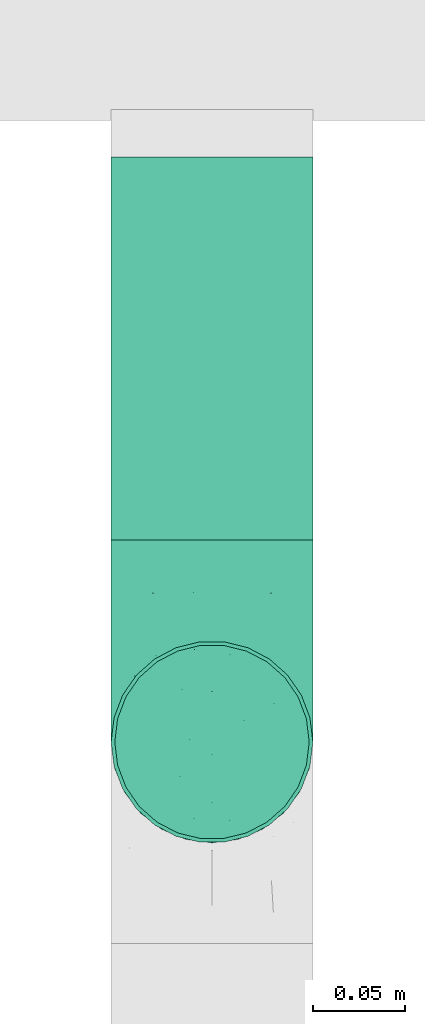
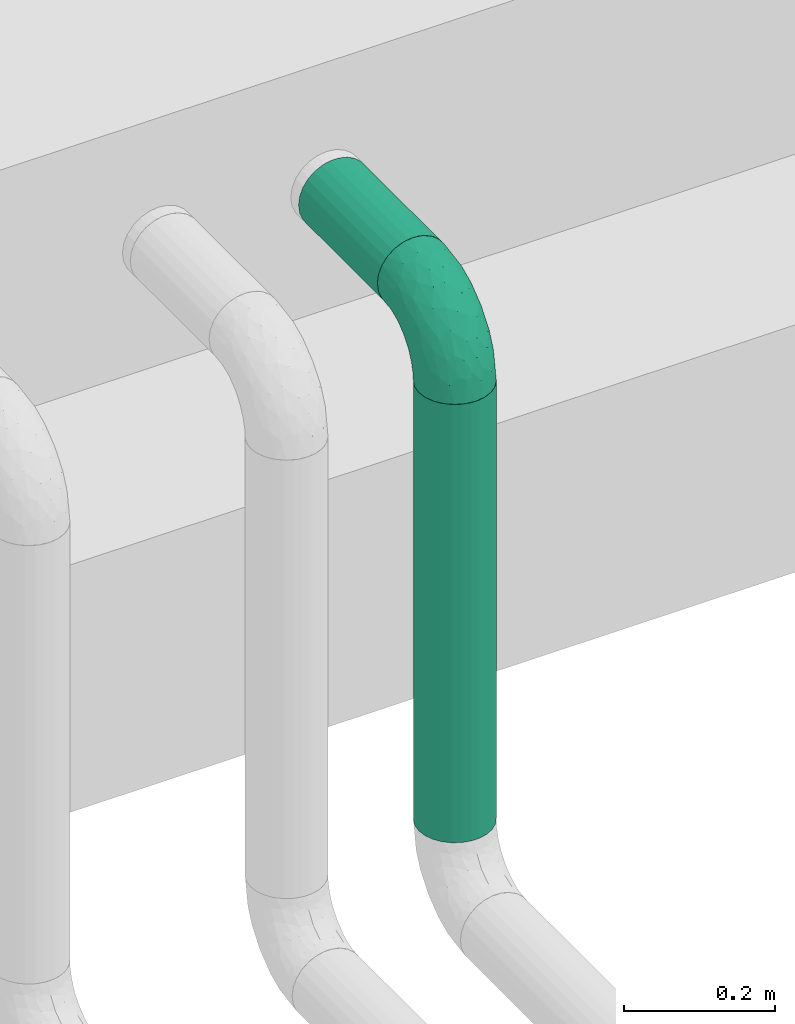
# One storey, part 11 of 91: 2 flow segments, 1 flow fitting.
"""IFC2X3 building model written with IfcOpenShell, lengths in millimetres."""

from ifc_helpers import new_model, entity, si_unit, converted_unit, derived_unit, direction, frame, origin_with_axes, origin_2d_with_axis, place, context, subcontext, project, spatial, hollow_circle, extrude, open_shell, surface_model, source, transform, mapped, material, layer, layer_set, layer_usage, type_object, element, save


model = new_model("IFC2X3")

# Units and contexts
model_context = context("Model", 3, precision=1e-05, world=origin_with_axes(), true_north=direction((0.0, 1.0)))
body_context = subcontext(model_context, "Body", "Model", "MODEL_VIEW")
ifc_project = project(units=[si_unit("AREAUNIT", "SQUARE_METRE"), si_unit("VOLUMEUNIT", "CUBIC_METRE", prefix="DECI"), si_unit("TIMEUNIT", "SECOND"), si_unit("THERMODYNAMICTEMPERATUREUNIT", "DEGREE_CELSIUS"), si_unit("PRESSUREUNIT", "PASCAL"), si_unit("MASSUNIT", "GRAM", prefix="KILO"), si_unit("LENGTHUNIT", "METRE", prefix="MILLI"), si_unit("POWERUNIT", "WATT"), si_unit("ELECTRICCURRENTUNIT", "AMPERE"), si_unit("ELECTRICVOLTAGEUNIT", "VOLT"), derived_unit("VOLUMETRICFLOWRATEUNIT", [(si_unit("VOLUMEUNIT", "CUBIC_METRE", prefix="DECI"), 1), (si_unit("TIMEUNIT", "SECOND"), -1)]), derived_unit("LINEARVELOCITYUNIT", [(si_unit("LENGTHUNIT", "METRE"), 1), (si_unit("TIMEUNIT", "SECOND"), -1)]), derived_unit("MASSDENSITYUNIT", [(si_unit("MASSUNIT", "GRAM", prefix="KILO"), 1), (si_unit("VOLUMEUNIT", "CUBIC_METRE"), -1)]), converted_unit("PLANEANGLEUNIT", "DEGREE", entity("IfcRatioMeasure", 0.01745), si_unit("PLANEANGLEUNIT", "RADIAN"), dimensions=[0, 0, 0, 0, 0, 0, 0])], contexts=[model_context])

# Site, building, storey
site_placement = place(None, origin_with_axes())
site = spatial("IfcSite", under=ifc_project, at=site_placement, CompositionType="ELEMENT")
building_placement = place(site_placement, origin_with_axes())
building = spatial("IfcBuilding", under=site, at=building_placement, Name="mc-building", CompositionType="ELEMENT")
storey_placement = place(building_placement, frame((0.0, 0.0, 8700.0), z_axis=(0.0, 0.0, 1.0), x_axis=(1.0, 0.0, 0.0)))
storey = spatial("IfcBuildingStorey", under=building, at=storey_placement, CompositionType="ELEMENT", Elevation=8700.0)

# Flow segments
ifc_material = material(Name="FZ1")
ifc_layer = layer(ifc_material, 0.0)
ifc_layer_set = layer_set([ifc_layer], Name="FZ1")
ifc_layer_usage = layer_usage(ifc_layer_set, "AXIS1", "POSITIVE", 0.0)
duct_segment_type = type_object("IfcDuctSegmentType", PredefinedType="RIGIDSEGMENT")
shared_shape_1 = source(origin_with_axes(), body_context, "Body", "SweptSolid", [
    extrude(hollow_circle(Radius=55.0, WallThickness=2.0, at=origin_2d_with_axis()), frame((0.0, 0.0, 0.0), z_axis=(1.0, 0.0, 0.0), x_axis=(0.0, 1.0, 0.0)), (0.0, 0.0, 1.0), 709.0),
])
flow_segment_1_placement = place(storey_placement, frame((9245.0, 2612.35324, 1234.0), z_axis=(0.0, 1.0, 0.0), x_axis=(0.0, 0.0, -1.0)))
element("IfcFlowSegment", 1, at=flow_segment_1_placement, inside=storey, type_object=duct_segment_type, material=ifc_layer_usage, context=body_context, shape_type="MappedRepresentation", body=[
    mapped(shared_shape_1, transform((0.0, 0.0, 0.0), scale=1.0)),
])
shared_shape_2 = source(origin_with_axes(), body_context, "Body", "SweptSolid", [
    extrude(hollow_circle(Radius=55.0, WallThickness=2.0, at=origin_2d_with_axis()), frame((0.0, 0.0, 0.0), z_axis=(1.0, 0.0, 0.0), x_axis=(0.0, 1.0, 0.0)), (0.0, 0.0, 1.0), 208.9),
])
flow_segment_2_placement = place(storey_placement, frame((9245.0, 2931.20513, 1344.0), z_axis=(0.0, 0.0, 1.0), x_axis=(0.0, -1.0, 0.0)))
element("IfcFlowSegment", 2, at=flow_segment_2_placement, inside=storey, type_object=duct_segment_type, material=ifc_layer_usage, context=body_context, shape_type="MappedRepresentation", body=[
    mapped(shared_shape_2, transform((0.0, 0.0, 0.0), scale=1.0, scale2=1.0, scale3=1.0, uniform=False)),
])

# Flow fitting
duct_fitting_type = type_object("IfcDuctFittingType", Name="BU", PredefinedType="BEND")
shared_shape_3 = source(origin_with_axes(), body_context, "Body", "SurfaceModel", [
    surface_model("IfcShellBasedSurfaceModel", [(-110.0, 0.0, -55.0), (-110.0, -14.23505, -53.12592), (-110.0, 14.23505, -53.12592), (-110.0, 53.12592, 14.23505), (-110.0, 27.5, -47.63139), (-110.0, 38.89087, -38.89087), (-110.0, -55.0, 0.0), (-110.0, -53.12592, 14.23505), (-110.0, -38.89087, -38.89087), (-110.0, -27.5, -47.63139), (-110.0, -53.12592, -14.23505), (-110.0, -47.63139, -27.5), (-110.0, -14.23505, 53.12592), (-110.0, 14.23505, 53.12592), (-110.0, 27.5, 47.63139), (-110.0, -47.63139, 27.5), (-110.0, -38.89087, 38.89087), (-110.0, -27.5, 47.63139), (-110.0, 0.0, 55.0), (-110.0, 55.0, 0.0), (-110.0, 53.12592, -14.23505), (-110.0, 47.63139, -27.5), (-110.0, 47.63139, 27.5), (-110.0, 38.89087, 38.89087), (-14.23505, 110.0, -53.12592), (-55.0, 110.0, 0.0), (0.0, 110.0, -55.0), (-27.5, 110.0, -47.63139), (-38.89087, 110.0, -38.89087), (-47.63139, 110.0, -27.5), (38.89087, 110.0, -38.89087), (53.12592, 110.0, 14.23505), (27.5, 110.0, -47.63139), (14.23505, 110.0, -53.12592), (47.63139, 110.0, -27.5), (53.12592, 110.0, -14.23505), (55.0, 110.0, 0.0), (-53.12592, 110.0, -14.23505), (-53.12592, 110.0, 14.23505), (-47.63139, 110.0, 27.5), (-38.89087, 110.0, 38.89087), (-27.5, 110.0, 47.63139), (0.0, 110.0, 55.0), (-14.23505, 110.0, 53.12592), (38.89087, 110.0, 38.89087), (47.63139, 110.0, 27.5), (27.5, 110.0, 47.63139), (14.23505, 110.0, 53.12592), (-64.21732, 48.68956, 43.63444), (-76.6405, 38.18013, 45.55988), (-60.44912, 32.56953, 51.94617), (-76.00813, 5.38378, 55.0), (-90.15553, 11.94394, 54.09138), (-78.5998, 26.77405, 50.81338), (-70.18771, 18.55163, 54.03432), (-75.55424, 54.2118, 32.41257), (-93.27622, 45.77614, 33.48188), (-96.12334, 22.13664, 50.81337), (-21.00813, 45.34362, 55.0), (-18.36258, 70.48427, 54.04484), (-32.04182, 59.64019, 52.24446), (-63.88653, 74.77858, 17.99134), (-74.66383, 63.08407, 19.92123), (-63.60674, 66.07878, 29.97482), (-99.597, 52.72185, 18.52927), (-93.11138, 56.59448, 10.50359), (-98.21577, 57.34403, 0.0), (-53.42855, 92.60092, 21.04759), (-88.54852, 54.8376, 21.04759), (-11.86161, 90.23965, 54.10313), (-5.38378, 76.00813, 55.0), (-57.34403, 98.21577, 0.0), (-56.64619, 93.12774, 10.22088), (-45.34362, 21.00813, 55.0), (-44.60838, 44.60838, 52.13415), (-92.68484, 35.46673, 43.63443), (-22.25266, 95.40765, 50.81337), (-35.97783, 90.61597, 43.63443), (-43.70931, 69.58671, 44.47149), (-27.23711, 77.39884, 50.81337), (-57.2828, 79.3123, 24.9774), (-58.67786, 84.31125, 16.04456), (-82.93277, 60.36161, 12.91784), (-49.88337, 54.51816, 47.224), (-74.57753, 66.83759, 9.55742), (-45.35812, 94.97281, 33.48188), (-59.18663, 88.95241, 0.0), (-51.517, 78.6292, 33.48188), (-65.14788, 80.03077, 0.0), (-56.45322, 62.06476, 39.63545), (-88.95241, 59.18663, 0.0), (-71.10913, 71.10913, 0.0), (-80.03077, 65.14788, 0.0), (-94.9309, 45.36788, -33.48188), (-93.11358, 56.60141, -10.46614), (-99.64997, 52.79499, -18.30015), (-90.20425, 36.08686, -43.63443), (-79.99933, 46.56772, -37.92748), (-76.00813, 5.38378, -55.0), (-72.75364, 19.68651, -53.60527), (-45.34362, 21.00813, -55.0), (-21.91957, 65.12078, -53.85897), (-5.38378, 76.00813, -55.0), (-21.00813, 45.34362, -55.0), (-35.41876, 92.89265, -43.63443), (-91.10309, 11.02766, -54.21832), (-45.77614, 93.27622, -33.48188), (-90.50474, 23.21022, -50.81337), (-70.92854, 33.31794, -49.51754), (-78.52933, 63.35627, -11.73997), (-24.91508, 84.05606, -50.81337), (-88.78941, 54.74452, -21.04759), (-69.59921, 57.34866, -33.48187), (-73.36422, 62.46673, -22.94182), (-63.49062, 67.59111, -28.46929), (-56.59448, 93.11138, -10.50359), (-54.8376, 88.54852, -21.04759), (-54.10679, 75.85581, -32.31867), (-57.75956, 31.09612, -52.80882), (-52.72185, 99.597, -18.52927), (-12.62913, 89.46304, -53.99097), (-34.46825, 66.46123, -50.04329), (-43.9837, 43.9837, -52.42279), (-65.78527, 72.58348, -17.68796), (-70.34468, 43.65295, -44.21951), (-57.47001, 51.99467, -44.91465), (-60.72547, 82.29174, -12.88567), (-42.34915, 74.24548, -43.63444), (-57.25194, 63.5016, -38.08211), (-80.95344, 53.56991, -29.32027), (-52.32891, 4.55257, -54.0482), (32.52942, 47.13398, -30.48571), (14.88266, 20.92917, -33.7947), (14.95561, 36.05775, -42.26543), (30.24048, 70.09027, -41.7461), (19.3559, 65.35825, -48.00507), (-70.35075, -46.44478, -19.5952), (-47.13398, -32.52942, -30.48571), (-28.49299, -30.5778, -16.4009), (-4.55257, 52.32891, -54.0482), (-22.4954, 22.4954, -53.25347), (-75.47368, -11.22546, -52.60718), (-81.32209, -51.5606, -9.98467), (-80.81763, -41.84862, -32.14655), (-70.09027, -30.24048, -41.7461), (-36.05774, -14.95561, -42.26543), (-9.15831, -10.852, -27.8997), (-65.35825, -19.3559, -48.00507), (11.22546, 75.47368, -52.60718), (3.94376, 43.9333, -50.53315), (-13.39742, 13.39743, -48.13058), (-43.9333, -3.94376, -50.53315), (49.37776, 67.29486, 0.0), (41.8609, 47.82256, -9.92641), (50.20582, 74.51695, -9.9731), (18.93131, 11.7156, -17.56239), (-27.5, -32.89419, 0.0), (-1.23348, -12.25375, -12.18106), (41.84862, 80.81763, -32.14655), (35.70604, 41.31408, -20.38235), (46.44478, 70.35075, -19.5952), (32.89419, 27.5, 0.0), (6.67262, -6.67262, 0.0), (-67.29486, -49.37776, 0.0), (-50.36265, -42.95545, -9.51562), (-5.47251, 5.47251, -39.92906), (-70.35075, -46.44478, 19.5952), (-74.51695, -50.20582, 9.9731), (-41.31407, -35.70604, 20.38235), (-47.13398, -32.52942, 30.48571), (-80.81763, -41.84862, 32.14655), (-4.55257, 52.32891, 54.0482), (11.22546, 75.47368, 52.60718), (-43.9333, -3.94376, 50.53315), (-65.35825, -19.3559, 48.00507), (-36.05774, -14.95561, 42.26543), (-70.09027, -30.24048, 41.7461), (-11.7156, -18.93131, 17.56239), (30.5778, 28.49299, 16.4009), (12.25375, 1.23348, 12.18106), (51.5606, 81.32209, 9.98467), (42.95545, 50.36265, 9.51562), (-75.47368, -11.22546, 52.60718), (-52.32891, 4.55257, 54.0482), (3.94376, 43.9333, 50.53315), (-22.4954, 22.4954, 53.25347), (-13.39742, 13.39743, 48.13058), (10.852, 9.15831, 27.8997), (-20.92916, -14.88266, 33.79469), (-47.82256, -41.8609, 9.92641), (32.52942, 47.13398, 30.48571), (46.44478, 70.35075, 19.5952), (41.84862, 80.81763, 32.14655), (30.24048, 70.09027, 41.7461), (19.3559, 65.35825, 48.00507), (14.95561, 36.05775, 42.26543), (-5.47251, 5.47251, 39.92906)], [open_shell([[[0, 1, 2]], [[2, 3, 4]], [[4, 3, 5]], [[2, 6, 7]], [[8, 6, 9]], [[1, 9, 6]], [[10, 6, 11]], [[8, 11, 6]], [[6, 2, 1]], [[12, 13, 14]], [[15, 2, 7]], [[16, 17, 2]], [[2, 17, 12]], [[12, 18, 13]], [[19, 20, 3]], [[5, 3, 21]], [[20, 21, 3]], [[22, 3, 2]], [[23, 22, 2]], [[12, 14, 2]], [[2, 14, 23]], [[15, 16, 2]], [[24, 25, 26]], [[27, 25, 24]], [[25, 28, 29]], [[28, 25, 27]], [[30, 26, 31]], [[26, 30, 32]], [[32, 33, 26]], [[34, 31, 35]], [[31, 34, 30]], [[35, 31, 36]], [[29, 37, 25]], [[38, 39, 26]], [[39, 40, 26]], [[41, 42, 40]], [[42, 26, 40]], [[42, 41, 43]], [[26, 44, 45]], [[31, 26, 45]], [[26, 46, 44]], [[47, 46, 26]], [[42, 47, 26]], [[25, 38, 26]], [[48, 49, 50]], [[18, 51, 52]], [[53, 54, 50]], [[55, 56, 49]], [[56, 22, 23]], [[13, 57, 14]], [[58, 59, 60]], [[61, 62, 63]], [[3, 64, 65]], [[53, 52, 54]], [[3, 65, 66]], [[67, 39, 38]], [[56, 68, 64]], [[65, 64, 68]], [[69, 59, 70]], [[38, 71, 72]], [[73, 58, 74]], [[75, 49, 56]], [[76, 69, 43]], [[53, 57, 52]], [[77, 78, 79]], [[41, 76, 43]], [[43, 69, 42]], [[55, 68, 56]], [[23, 14, 75]], [[76, 77, 79]], [[80, 67, 81]], [[62, 82, 68]], [[60, 78, 83]], [[62, 84, 82]], [[85, 77, 40]], [[81, 67, 72]], [[86, 72, 71]], [[87, 85, 67]], [[61, 81, 88]], [[77, 41, 40]], [[78, 77, 87]], [[23, 75, 56]], [[83, 89, 48]], [[85, 40, 39]], [[62, 68, 55]], [[89, 87, 63]], [[83, 48, 50]], [[57, 75, 14]], [[49, 75, 53]], [[67, 85, 39]], [[87, 77, 85]], [[63, 62, 55]], [[89, 55, 48]], [[80, 63, 87]], [[66, 65, 90]], [[66, 19, 3]], [[84, 91, 92]], [[92, 90, 82]], [[65, 82, 90]], [[61, 84, 62]], [[92, 82, 84]], [[68, 82, 65]], [[3, 22, 64]], [[56, 64, 22]], [[38, 25, 71]], [[81, 72, 86]], [[38, 72, 67]], [[91, 61, 88]], [[80, 81, 61]], [[63, 80, 61]], [[67, 80, 87]], [[77, 76, 41]], [[79, 59, 69]], [[79, 69, 76]], [[42, 69, 70]], [[60, 59, 79]], [[58, 70, 59]], [[78, 60, 79]], [[58, 60, 74]], [[52, 57, 13]], [[75, 57, 53]], [[18, 52, 13]], [[52, 51, 54]], [[51, 73, 54]], [[50, 73, 74]], [[73, 50, 54]], [[50, 74, 83]], [[60, 83, 74]], [[89, 83, 78]], [[87, 89, 78]], [[55, 89, 63]], [[50, 49, 53]], [[55, 49, 48]], [[81, 86, 88]], [[91, 84, 61]], [[5, 21, 93]], [[90, 94, 66]], [[20, 94, 95]], [[96, 93, 97]], [[98, 99, 100]], [[96, 4, 5]], [[101, 102, 103]], [[28, 27, 104]], [[2, 105, 0]], [[104, 106, 28]], [[99, 105, 107]], [[108, 107, 96]], [[90, 109, 94]], [[107, 2, 4]], [[20, 66, 94]], [[27, 24, 110]], [[109, 111, 94]], [[112, 113, 114]], [[37, 115, 71]], [[116, 106, 117]], [[99, 118, 100]], [[116, 115, 119]], [[37, 119, 115]], [[24, 120, 110]], [[121, 110, 101]], [[119, 106, 116]], [[101, 110, 120]], [[122, 103, 100]], [[117, 123, 116]], [[124, 125, 108]], [[115, 116, 126]], [[106, 29, 28]], [[26, 102, 120]], [[127, 104, 110]], [[97, 124, 96]], [[125, 122, 118]], [[128, 127, 125]], [[96, 5, 93]], [[115, 126, 86]], [[117, 106, 127]], [[111, 113, 129]], [[95, 93, 21]], [[97, 129, 112]], [[110, 104, 27]], [[106, 104, 127]], [[96, 107, 4]], [[99, 107, 108]], [[99, 108, 118]], [[105, 99, 98]], [[112, 114, 128]], [[121, 125, 127]], [[20, 19, 66]], [[109, 90, 92]], [[94, 111, 95]], [[91, 123, 109]], [[129, 113, 112]], [[93, 95, 111]], [[21, 20, 95]], [[71, 115, 86]], [[71, 25, 37]], [[123, 91, 88]], [[126, 116, 123]], [[123, 88, 126]], [[86, 126, 88]], [[37, 29, 119]], [[106, 119, 29]], [[129, 93, 111]], [[124, 112, 125]], [[0, 105, 98]], [[107, 105, 2]], [[125, 118, 108]], [[100, 118, 122]], [[93, 129, 97]], [[113, 111, 109]], [[109, 123, 113]], [[114, 123, 117]], [[123, 114, 113]], [[128, 114, 117]], [[127, 128, 117]], [[112, 128, 125]], [[103, 122, 101]], [[110, 121, 127]], [[101, 122, 121]], [[125, 121, 122]], [[26, 120, 24]], [[101, 120, 102]], [[96, 124, 108]], [[92, 91, 109]], [[112, 124, 97]], [[100, 130, 98]], [[131, 132, 133]], [[32, 134, 135]], [[136, 137, 138]], [[139, 140, 103]], [[98, 141, 0]], [[142, 10, 136]], [[143, 144, 137]], [[6, 10, 142]], [[137, 145, 146]], [[144, 147, 145]], [[143, 136, 11]], [[11, 136, 10]], [[8, 143, 11]], [[148, 149, 139]], [[8, 9, 144]], [[9, 1, 147]], [[130, 141, 98]], [[103, 140, 100]], [[148, 135, 149]], [[150, 151, 140]], [[152, 153, 154]], [[130, 140, 151]], [[148, 26, 33]], [[147, 1, 141]], [[155, 146, 132]], [[156, 138, 157]], [[134, 30, 158]], [[150, 140, 149]], [[158, 30, 34]], [[30, 134, 32]], [[153, 159, 160]], [[131, 160, 159]], [[144, 145, 137]], [[36, 152, 154]], [[146, 138, 137]], [[155, 161, 162]], [[158, 160, 131]], [[133, 149, 135]], [[156, 163, 164]], [[163, 142, 164]], [[139, 103, 102]], [[153, 152, 161]], [[34, 35, 160]], [[162, 157, 155]], [[132, 165, 133]], [[157, 146, 155]], [[140, 130, 100]], [[141, 130, 151]], [[141, 151, 147]], [[141, 1, 0]], [[102, 26, 148]], [[140, 139, 149]], [[102, 148, 139]], [[135, 33, 32]], [[151, 150, 145]], [[9, 147, 144]], [[151, 145, 147]], [[145, 165, 146]], [[135, 148, 33]], [[133, 135, 134]], [[131, 133, 134]], [[133, 165, 150]], [[133, 150, 149]], [[145, 150, 165]], [[132, 131, 159]], [[146, 165, 132]], [[160, 158, 34]], [[134, 158, 131]], [[144, 143, 8]], [[136, 143, 137]], [[155, 153, 161]], [[154, 153, 160]], [[153, 155, 159]], [[132, 159, 155]], [[160, 35, 154]], [[36, 154, 35]], [[164, 136, 138]], [[6, 142, 163]], [[136, 164, 142]], [[156, 164, 138]], [[156, 157, 162]], [[146, 157, 138]], [[15, 7, 166]], [[6, 163, 167]], [[168, 169, 166]], [[166, 169, 170]], [[171, 172, 70]], [[173, 174, 175]], [[17, 176, 174]], [[177, 156, 162]], [[176, 16, 170]], [[170, 16, 15]], [[161, 178, 179]], [[152, 180, 181]], [[182, 173, 183]], [[18, 12, 182]], [[184, 185, 186]], [[183, 185, 73]], [[183, 73, 51]], [[177, 187, 188]], [[189, 168, 166]], [[187, 178, 190]], [[16, 176, 17]], [[161, 152, 181]], [[45, 191, 31]], [[45, 44, 192]], [[192, 191, 45]], [[180, 36, 31]], [[193, 194, 195]], [[46, 47, 194]], [[193, 195, 190]], [[193, 44, 46]], [[172, 42, 70]], [[185, 58, 73]], [[189, 163, 156]], [[163, 189, 167]], [[70, 58, 171]], [[184, 171, 185]], [[169, 188, 175]], [[180, 31, 191]], [[192, 193, 190]], [[191, 190, 178]], [[182, 174, 173]], [[194, 47, 172]], [[190, 195, 187]], [[186, 185, 173]], [[162, 179, 177]], [[188, 196, 175]], [[179, 187, 177]], [[185, 171, 58]], [[172, 171, 184]], [[172, 184, 194]], [[172, 47, 42]], [[51, 18, 182]], [[185, 183, 173]], [[51, 182, 183]], [[174, 12, 17]], [[184, 186, 195]], [[46, 194, 193]], [[184, 195, 194]], [[195, 196, 187]], [[174, 182, 12]], [[175, 174, 176]], [[169, 175, 176]], [[175, 196, 186]], [[175, 186, 173]], [[195, 186, 196]], [[188, 169, 168]], [[187, 196, 188]], [[166, 170, 15]], [[176, 170, 169]], [[193, 192, 44]], [[191, 192, 190]], [[177, 189, 156]], [[167, 189, 166]], [[189, 177, 168]], [[188, 168, 177]], [[166, 7, 167]], [[6, 167, 7]], [[181, 191, 178]], [[36, 180, 152]], [[191, 181, 180]], [[161, 181, 178]], [[161, 179, 162]], [[187, 179, 178]]])]),
])
flow_fitting_placement = place(storey_placement, frame((9245.0, 2612.35324, 1344.0), z_axis=(-1.0, 0.0, 0.0), x_axis=(0.0, 0.0, 1.0)))
element("IfcFlowFitting", 3, at=flow_fitting_placement, inside=storey, type_object=duct_fitting_type, Name="BU", context=body_context, shape_type="MappedRepresentation", body=[
    mapped(shared_shape_3, transform((0.0, 0.0, 0.0), scale=1.0)),
])

save(model, "model.ifc")
